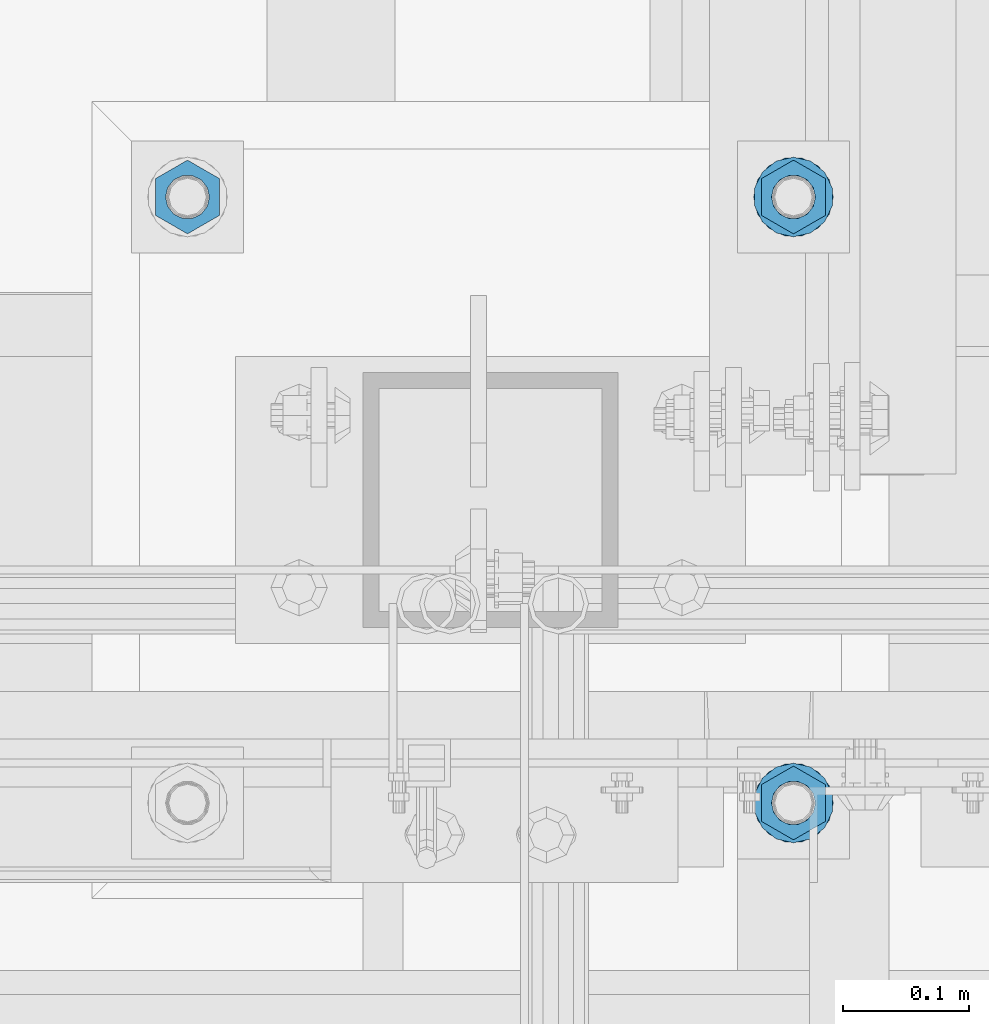
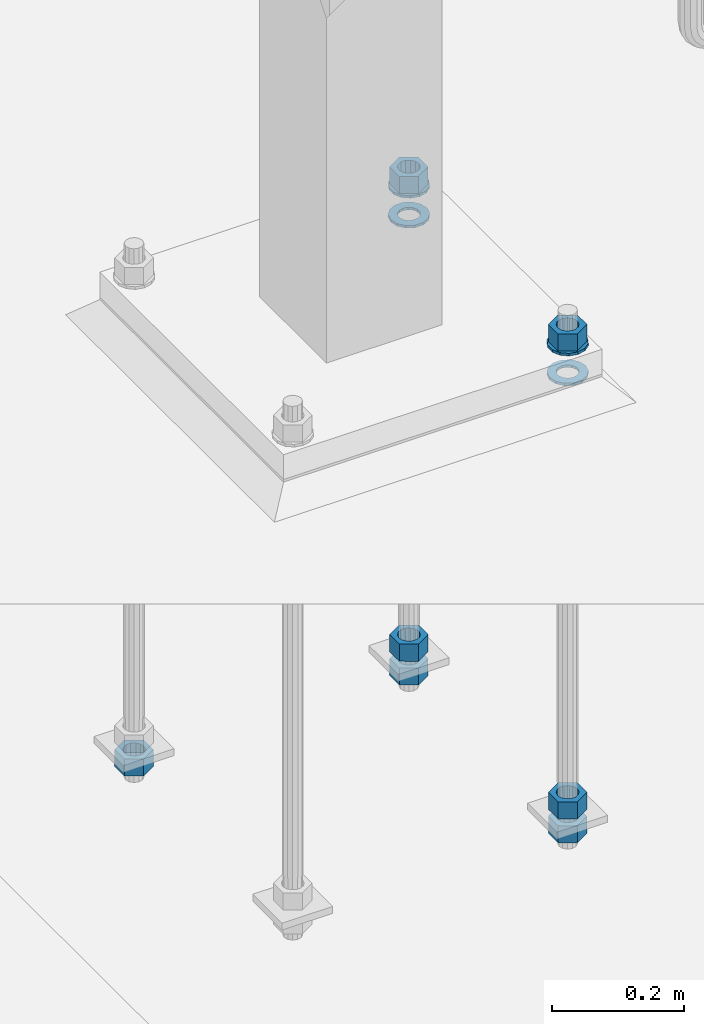
# One storey, part 900 of 1876: 11 columns, 1 element without a shape of its own.
"""IFC2X3 building model written with IfcOpenShell, lengths in millimetres."""

from ifc_helpers import new_model, si_unit, frame, origin_with_axes, place, context, subcontext, project, spatial, faceted_brep, material, type_object, element, aggregate, save


model = new_model("IFC2X3")

# Units and contexts
model_context = context("Model", 3, precision=1e-05, world=origin_with_axes())
body_context = subcontext(model_context, "Body", "Model", "MODEL_VIEW")
ifc_project = project(units=[si_unit("LENGTHUNIT", "METRE", prefix="MILLI"), si_unit("AREAUNIT", "SQUARE_METRE"), si_unit("VOLUMEUNIT", "CUBIC_METRE"), si_unit("MASSUNIT", "GRAM", prefix="KILO"), si_unit("TIMEUNIT", "SECOND"), si_unit("PLANEANGLEUNIT", "RADIAN"), si_unit("SOLIDANGLEUNIT", "STERADIAN"), si_unit("THERMODYNAMICTEMPERATUREUNIT", "DEGREE_CELSIUS"), si_unit("LUMINOUSINTENSITYUNIT", "LUMEN")], contexts=[model_context])

# Site, building, storey
site_placement = place(None, origin_with_axes())
site = spatial("IfcSite", under=ifc_project, at=site_placement, CompositionType="ELEMENT")
building_placement = place(site_placement, origin_with_axes())
building = spatial("IfcBuilding", under=site, at=building_placement, Name="Undefined", CompositionType="ELEMENT")
storey_placement = place(building_placement, origin_with_axes())
storey = spatial("IfcBuildingStorey", under=building, at=storey_placement, Name="Undefined", CompositionType="ELEMENT", Elevation=0.0)

# Assembly, columns
assembly_placement = place(storey_placement, origin_with_axes())
assembly = element("IfcElementAssembly", 1, at=assembly_placement, inside=storey, Name="TEMPLATE", AssemblyPlace="NOTDEFINED", PredefinedType="RIGID_FRAME")
ifc_material_1 = material(Name="STEEL/F436")
column_type_1 = type_object("IfcColumnType", Name="1-1/4_WASHER", PredefinedType="NOTDEFINED")
column_1_placement = place(assembly_placement, frame((1968.5, -4813.3, 38.1), z_axis=(0.0, -1.0, 0.0), x_axis=(0.0, 0.0, -1.0)))
column_1 = element("IfcColumn", 2, at=column_1_placement, type_object=column_type_1, material=ifc_material_1, Name="WASHER", ObjectType="1-1/4_WASHER", context=body_context, shape_type="Brep", body=[
    faceted_brep([(0.0, -31.75, 0.0), (0.0, -28.6057615559018, -13.7758087169823), (4.7625, -28.6057615559018, -13.7758087169823), (4.7625, -31.75, 0.0), (0.0, -19.7958012090148, -24.8231495683603), (4.7625, -19.7958012090148, -24.8231495683603), (0.0, -7.06503965311299, -30.9539612117733), (4.7625, -7.06503965311299, -30.9539612117733), (0.0, 7.06503965311322, -30.9539612117733), (4.7625, 7.06503965311322, -30.9539612117733), (0.0, 19.7958012090151, -24.8231495683603), (4.7625, 19.7958012090151, -24.8231495683603), (0.0, 28.6057615559021, -13.7758087169823), (4.7625, 28.6057615559021, -13.7758087169823), (0.0, 31.75, 0.0), (4.7625, 31.75, 0.0), (0.0, 28.6057615559018, 13.7758087169823), (4.7625, 28.6057615559018, 13.7758087169823), (0.0, 19.7958012090148, 24.8231495683603), (4.7625, 19.7958012090148, 24.8231495683603), (0.0, 7.06503965311299, 30.9539612117733), (4.7625, 7.06503965311299, 30.9539612117733), (0.0, -7.06503965311322, 30.9539612117733), (4.7625, -7.06503965311322, 30.9539612117733), (0.0, -19.7958012090151, 24.8231495683603), (4.7625, -19.7958012090151, 24.8231495683603), (0.0, -28.6057615559021, 13.7758087169823), (4.7625, -28.6057615559021, 13.7758087169823), (0.0, 0.0, 17.4599990844727), (0.0, 7.57560968776033, 15.7309156087144), (4.7625, 7.57560968776011, 15.7309156087149), (4.7625, 0.0, 17.4599990844727), (0.0, 13.6507769681039, 10.8861313696314), (4.7625, 13.6507769681036, 10.8861313696316), (0.0, 17.0222404541219, 3.88521530315325), (4.7625, 17.0222404541214, 3.88521530315302), (0.0, 17.0222404541219, -3.88521530315325), (4.7625, 17.0222404541214, -3.88521530315302), (0.0, 13.6507769681039, -10.8861313696316), (4.7625, 13.6507769681036, -10.8861313696316), (0.0, 7.57560968776033, -15.7309156087147), (4.7625, 7.57560968776011, -15.7309156087149), (0.0, 0.0, -17.4599990844727), (4.7625, 0.0, -17.4599990844727), (0.0, -7.57560968776033, -15.7309156087144), (4.7625, -7.57560968776011, -15.7309156087149), (0.0, -13.6507769681039, -10.8861313696314), (4.7625, -13.6507769681036, -10.8861313696316), (0.0, -17.0222404541219, -3.88521530315325), (4.7625, -17.0222404541214, -3.88521530315302), (0.0, -17.0222404541219, 3.88521530315325), (4.7625, -17.0222404541214, 3.88521530315302), (0.0, -13.6507769681039, 10.8861313696316), (4.7625, -13.6507769681036, 10.8861313696316), (0.0, -7.57560968776033, 15.7309156087147), (4.7625, -7.57560968776011, 15.7309156087149)], [[[0, 1, 2, 3]], [[1, 4, 5, 2]], [[4, 6, 7, 5]], [[6, 8, 9, 7]], [[8, 10, 11, 9]], [[10, 12, 13, 11]], [[12, 14, 15, 13]], [[14, 16, 17, 15]], [[16, 18, 19, 17]], [[18, 20, 21, 19]], [[20, 22, 23, 21]], [[22, 24, 25, 23]], [[24, 26, 27, 25]], [[26, 0, 3, 27]], [[28, 29, 30, 31]], [[29, 32, 33, 30]], [[32, 34, 35, 33]], [[34, 36, 37, 35]], [[36, 38, 39, 37]], [[38, 40, 41, 39]], [[40, 42, 43, 41]], [[42, 44, 45, 43]], [[44, 46, 47, 45]], [[46, 48, 49, 47]], [[48, 50, 51, 49]], [[50, 52, 53, 51]], [[52, 54, 55, 53]], [[54, 28, 31, 55]], [[5, 7, 9, 11, 13, 15, 17, 19, 21, 23, 25, 27, 3, 2], [33, 35, 37, 39, 41, 43, 45, 47, 49, 51, 53, 55, 31, 30]], [[26, 24, 22, 20, 18, 16, 14, 12, 10, 8, 6, 4, 1, 0], [54, 52, 50, 48, 46, 44, 42, 40, 38, 36, 34, 32, 29, 28]]]),
])
column_2_placement = place(assembly_placement, frame((1968.5, -4330.7, 38.1), z_axis=(0.0, -1.0, 0.0), x_axis=(0.0, 0.0, -1.0)))
column_2 = element("IfcColumn", 3, at=column_2_placement, type_object=column_type_1, material=ifc_material_1, Name="WASHER", ObjectType="1-1/4_WASHER", context=body_context, shape_type="Brep", body=[
    faceted_brep([(0.0, -31.75, 0.0), (0.0, -28.6057615559018, -13.7758087169823), (4.7625, -28.6057615559018, -13.7758087169823), (4.7625, -31.75, 0.0), (0.0, -19.7958012090148, -24.8231495683603), (4.7625, -19.7958012090148, -24.8231495683603), (0.0, -7.06503965311299, -30.9539612117733), (4.7625, -7.06503965311299, -30.9539612117733), (0.0, 7.06503965311322, -30.9539612117733), (4.7625, 7.06503965311322, -30.9539612117733), (0.0, 19.7958012090151, -24.8231495683603), (4.7625, 19.7958012090151, -24.8231495683603), (0.0, 28.6057615559021, -13.7758087169823), (4.7625, 28.6057615559021, -13.7758087169823), (0.0, 31.75, 0.0), (4.7625, 31.75, 0.0), (0.0, 28.6057615559018, 13.7758087169823), (4.7625, 28.6057615559018, 13.7758087169823), (0.0, 19.7958012090148, 24.8231495683603), (4.7625, 19.7958012090148, 24.8231495683603), (0.0, 7.06503965311299, 30.9539612117733), (4.7625, 7.06503965311299, 30.9539612117733), (0.0, -7.06503965311322, 30.9539612117733), (4.7625, -7.06503965311322, 30.9539612117733), (0.0, -19.7958012090151, 24.8231495683603), (4.7625, -19.7958012090151, 24.8231495683603), (0.0, -28.6057615559021, 13.7758087169823), (4.7625, -28.6057615559021, 13.7758087169823), (0.0, 0.0, 17.4599990844727), (0.0, 7.57560968776033, 15.7309156087144), (4.7625, 7.57560968776011, 15.7309156087149), (4.7625, 0.0, 17.4599990844727), (0.0, 13.6507769681039, 10.8861313696314), (4.7625, 13.6507769681036, 10.8861313696316), (0.0, 17.0222404541219, 3.88521530315325), (4.7625, 17.0222404541214, 3.88521530315302), (0.0, 17.0222404541219, -3.88521530315325), (4.7625, 17.0222404541214, -3.88521530315302), (0.0, 13.6507769681039, -10.8861313696316), (4.7625, 13.6507769681036, -10.8861313696316), (0.0, 7.57560968776033, -15.7309156087147), (4.7625, 7.57560968776011, -15.7309156087149), (0.0, 0.0, -17.4599990844727), (4.7625, 0.0, -17.4599990844727), (0.0, -7.57560968776033, -15.7309156087144), (4.7625, -7.57560968776011, -15.7309156087149), (0.0, -13.6507769681039, -10.8861313696314), (4.7625, -13.6507769681036, -10.8861313696316), (0.0, -17.0222404541219, -3.88521530315325), (4.7625, -17.0222404541214, -3.88521530315302), (0.0, -17.0222404541219, 3.88521530315325), (4.7625, -17.0222404541214, 3.88521530315302), (0.0, -13.6507769681039, 10.8861313696316), (4.7625, -13.6507769681036, 10.8861313696316), (0.0, -7.57560968776033, 15.7309156087147), (4.7625, -7.57560968776011, 15.7309156087149)], [[[0, 1, 2, 3]], [[1, 4, 5, 2]], [[4, 6, 7, 5]], [[6, 8, 9, 7]], [[8, 10, 11, 9]], [[10, 12, 13, 11]], [[12, 14, 15, 13]], [[14, 16, 17, 15]], [[16, 18, 19, 17]], [[18, 20, 21, 19]], [[20, 22, 23, 21]], [[22, 24, 25, 23]], [[24, 26, 27, 25]], [[26, 0, 3, 27]], [[28, 29, 30, 31]], [[29, 32, 33, 30]], [[32, 34, 35, 33]], [[34, 36, 37, 35]], [[36, 38, 39, 37]], [[38, 40, 41, 39]], [[40, 42, 43, 41]], [[42, 44, 45, 43]], [[44, 46, 47, 45]], [[46, 48, 49, 47]], [[48, 50, 51, 49]], [[50, 52, 53, 51]], [[52, 54, 55, 53]], [[54, 28, 31, 55]], [[5, 7, 9, 11, 13, 15, 17, 19, 21, 23, 25, 27, 3, 2], [33, 35, 37, 39, 41, 43, 45, 47, 49, 51, 53, 55, 31, 30]], [[26, 24, 22, 20, 18, 16, 14, 12, 10, 8, 6, 4, 1, 0], [54, 52, 50, 48, 46, 44, 42, 40, 38, 36, 34, 32, 29, 28]]]),
])
column_3_placement = place(assembly_placement, frame((1968.5, -4813.3, 93.6625), z_axis=(1.0, 0.0, 0.0), x_axis=(0.0, 0.0, -1.0)))
column_3 = element("IfcColumn", 4, at=column_3_placement, type_object=column_type_1, material=ifc_material_1, Name="WASHER", ObjectType="1-1/4_WASHER", context=body_context, shape_type="Brep", body=[
    faceted_brep([(0.0, -31.75, 0.0), (0.0, -28.6057615559018, -13.7758087169823), (4.7625, -28.6057615559018, -13.7758087169823), (4.7625, -31.75, 0.0), (0.0, -19.7958012090148, -24.8231495683603), (4.7625, -19.7958012090148, -24.8231495683603), (0.0, -7.06503965311299, -30.9539612117733), (4.7625, -7.06503965311299, -30.9539612117733), (0.0, 7.06503965311322, -30.9539612117733), (4.7625, 7.06503965311322, -30.9539612117733), (0.0, 19.7958012090151, -24.8231495683603), (4.7625, 19.7958012090151, -24.8231495683603), (0.0, 28.6057615559021, -13.7758087169823), (4.7625, 28.6057615559021, -13.7758087169823), (0.0, 31.75, 0.0), (4.7625, 31.75, 0.0), (0.0, 28.6057615559018, 13.7758087169823), (4.7625, 28.6057615559018, 13.7758087169823), (0.0, 19.7958012090148, 24.8231495683603), (4.7625, 19.7958012090148, 24.8231495683603), (0.0, 7.06503965311299, 30.9539612117733), (4.7625, 7.06503965311299, 30.9539612117733), (0.0, -7.06503965311322, 30.9539612117733), (4.7625, -7.06503965311322, 30.9539612117733), (0.0, -19.7958012090151, 24.8231495683603), (4.7625, -19.7958012090151, 24.8231495683603), (0.0, -28.6057615559021, 13.7758087169823), (4.7625, -28.6057615559021, 13.7758087169823), (0.0, 0.0, 17.4599990844727), (0.0, 7.57560968776033, 15.7309156087144), (4.7625, 7.57560968776011, 15.7309156087149), (4.7625, 0.0, 17.4599990844727), (0.0, 13.6507769681039, 10.8861313696314), (4.7625, 13.6507769681036, 10.8861313696316), (0.0, 17.0222404541219, 3.88521530315325), (4.7625, 17.0222404541214, 3.88521530315302), (0.0, 17.0222404541219, -3.88521530315325), (4.7625, 17.0222404541214, -3.88521530315302), (0.0, 13.6507769681039, -10.8861313696316), (4.7625, 13.6507769681036, -10.8861313696316), (0.0, 7.57560968776033, -15.7309156087147), (4.7625, 7.57560968776011, -15.7309156087149), (0.0, 0.0, -17.4599990844727), (4.7625, 0.0, -17.4599990844727), (0.0, -7.57560968776033, -15.7309156087144), (4.7625, -7.57560968776011, -15.7309156087149), (0.0, -13.6507769681039, -10.8861313696314), (4.7625, -13.6507769681036, -10.8861313696316), (0.0, -17.0222404541219, -3.88521530315325), (4.7625, -17.0222404541214, -3.88521530315302), (0.0, -17.0222404541219, 3.88521530315325), (4.7625, -17.0222404541214, 3.88521530315302), (0.0, -13.6507769681039, 10.8861313696316), (4.7625, -13.6507769681036, 10.8861313696316), (0.0, -7.57560968776033, 15.7309156087147), (4.7625, -7.57560968776011, 15.7309156087149)], [[[0, 1, 2, 3]], [[1, 4, 5, 2]], [[4, 6, 7, 5]], [[6, 8, 9, 7]], [[8, 10, 11, 9]], [[10, 12, 13, 11]], [[12, 14, 15, 13]], [[14, 16, 17, 15]], [[16, 18, 19, 17]], [[18, 20, 21, 19]], [[20, 22, 23, 21]], [[22, 24, 25, 23]], [[24, 26, 27, 25]], [[26, 0, 3, 27]], [[28, 29, 30, 31]], [[29, 32, 33, 30]], [[32, 34, 35, 33]], [[34, 36, 37, 35]], [[36, 38, 39, 37]], [[38, 40, 41, 39]], [[40, 42, 43, 41]], [[42, 44, 45, 43]], [[44, 46, 47, 45]], [[46, 48, 49, 47]], [[48, 50, 51, 49]], [[50, 52, 53, 51]], [[52, 54, 55, 53]], [[54, 28, 31, 55]], [[5, 7, 9, 11, 13, 15, 17, 19, 21, 23, 25, 27, 3, 2], [33, 35, 37, 39, 41, 43, 45, 47, 49, 51, 53, 55, 31, 30]], [[26, 24, 22, 20, 18, 16, 14, 12, 10, 8, 6, 4, 1, 0], [54, 52, 50, 48, 46, 44, 42, 40, 38, 36, 34, 32, 29, 28]]]),
])
column_4_placement = place(assembly_placement, frame((1968.5, -4330.7, 93.6625), z_axis=(-1.0, 0.0, 0.0), x_axis=(0.0, 0.0, -1.0)))
column_4 = element("IfcColumn", 5, at=column_4_placement, type_object=column_type_1, material=ifc_material_1, Name="WASHER", ObjectType="1-1/4_WASHER", context=body_context, shape_type="Brep", body=[
    faceted_brep([(0.0, -31.75, 0.0), (0.0, -28.6057615559018, -13.7758087169823), (4.7625, -28.6057615559018, -13.7758087169823), (4.7625, -31.75, 0.0), (0.0, -19.7958012090148, -24.8231495683603), (4.7625, -19.7958012090148, -24.8231495683603), (0.0, -7.06503965311299, -30.9539612117733), (4.7625, -7.06503965311299, -30.9539612117733), (0.0, 7.06503965311322, -30.9539612117733), (4.7625, 7.06503965311322, -30.9539612117733), (0.0, 19.7958012090151, -24.8231495683603), (4.7625, 19.7958012090151, -24.8231495683603), (0.0, 28.6057615559021, -13.7758087169823), (4.7625, 28.6057615559021, -13.7758087169823), (0.0, 31.75, 0.0), (4.7625, 31.75, 0.0), (0.0, 28.6057615559018, 13.7758087169823), (4.7625, 28.6057615559018, 13.7758087169823), (0.0, 19.7958012090148, 24.8231495683603), (4.7625, 19.7958012090148, 24.8231495683603), (0.0, 7.06503965311299, 30.9539612117733), (4.7625, 7.06503965311299, 30.9539612117733), (0.0, -7.06503965311322, 30.9539612117733), (4.7625, -7.06503965311322, 30.9539612117733), (0.0, -19.7958012090151, 24.8231495683603), (4.7625, -19.7958012090151, 24.8231495683603), (0.0, -28.6057615559021, 13.7758087169823), (4.7625, -28.6057615559021, 13.7758087169823), (0.0, 0.0, 17.4599990844727), (0.0, 7.57560968776033, 15.7309156087144), (4.7625, 7.57560968776011, 15.7309156087149), (4.7625, 0.0, 17.4599990844727), (0.0, 13.6507769681039, 10.8861313696314), (4.7625, 13.6507769681036, 10.8861313696316), (0.0, 17.0222404541219, 3.88521530315325), (4.7625, 17.0222404541214, 3.88521530315302), (0.0, 17.0222404541219, -3.88521530315325), (4.7625, 17.0222404541214, -3.88521530315302), (0.0, 13.6507769681039, -10.8861313696316), (4.7625, 13.6507769681036, -10.8861313696316), (0.0, 7.57560968776033, -15.7309156087147), (4.7625, 7.57560968776011, -15.7309156087149), (0.0, 0.0, -17.4599990844727), (4.7625, 0.0, -17.4599990844727), (0.0, -7.57560968776033, -15.7309156087144), (4.7625, -7.57560968776011, -15.7309156087149), (0.0, -13.6507769681039, -10.8861313696314), (4.7625, -13.6507769681036, -10.8861313696316), (0.0, -17.0222404541219, -3.88521530315325), (4.7625, -17.0222404541214, -3.88521530315302), (0.0, -17.0222404541219, 3.88521530315325), (4.7625, -17.0222404541214, 3.88521530315302), (0.0, -13.6507769681039, 10.8861313696316), (4.7625, -13.6507769681036, 10.8861313696316), (0.0, -7.57560968776033, 15.7309156087147), (4.7625, -7.57560968776011, 15.7309156087149)], [[[0, 1, 2, 3]], [[1, 4, 5, 2]], [[4, 6, 7, 5]], [[6, 8, 9, 7]], [[8, 10, 11, 9]], [[10, 12, 13, 11]], [[12, 14, 15, 13]], [[14, 16, 17, 15]], [[16, 18, 19, 17]], [[18, 20, 21, 19]], [[20, 22, 23, 21]], [[22, 24, 25, 23]], [[24, 26, 27, 25]], [[26, 0, 3, 27]], [[28, 29, 30, 31]], [[29, 32, 33, 30]], [[32, 34, 35, 33]], [[34, 36, 37, 35]], [[36, 38, 39, 37]], [[38, 40, 41, 39]], [[40, 42, 43, 41]], [[42, 44, 45, 43]], [[44, 46, 47, 45]], [[46, 48, 49, 47]], [[48, 50, 51, 49]], [[50, 52, 53, 51]], [[52, 54, 55, 53]], [[54, 28, 31, 55]], [[5, 7, 9, 11, 13, 15, 17, 19, 21, 23, 25, 27, 3, 2], [33, 35, 37, 39, 41, 43, 45, 47, 49, 51, 53, 55, 31, 30]], [[26, 24, 22, 20, 18, 16, 14, 12, 10, 8, 6, 4, 1, 0], [54, 52, 50, 48, 46, 44, 42, 40, 38, 36, 34, 32, 29, 28]]]),
])
ifc_material_2 = material(Name="STEEL/A563")
column_type_2 = type_object("IfcColumnType", Name="1-1/4_HEAVY_HEX_NUT", PredefinedType="NOTDEFINED")
column_5_placement = place(assembly_placement, frame((1968.5, -4813.3, -742.95), z_axis=(1.0, 0.0, 0.0), x_axis=(0.0, 0.0, -1.0)))
column_5 = element("IfcColumn", 6, at=column_5_placement, type_object=column_type_2, material=ifc_material_2, Name="NUT", ObjectType="1-1/4_HEAVY_HEX_NUT", context=body_context, shape_type="Brep", body=[
    faceted_brep([(0.0, -29.3700008392334, 0.0), (0.0, -14.6800003051758, -25.4300003051758), (31.75, -14.6800003051758, -25.4300003051758), (31.75, -29.3700008392334, 0.0), (0.0, 14.6800003051758, -25.4300003051758), (31.75, 14.6800003051758, -25.4300003051758), (0.0, 29.3700008392334, 0.0), (31.75, 29.3700008392334, 0.0), (0.0, 14.6800003051758, 25.4300003051758), (31.75, 14.6800003051758, 25.4300003051758), (0.0, -14.6800003051758, 25.4300003051758), (31.75, -14.6800003051758, 25.4300003051758), (0.0, 0.0, 17.4599990844727), (0.0, 7.57560968776033, 15.7309156087144), (31.75, 7.57560968776033, 15.7309156087144), (31.75, 0.0, 17.4599990844727), (0.0, 13.6507769681039, 10.8861313696314), (31.75, 13.6507769681039, 10.8861313696314), (0.0, 17.0222404541219, 3.88521530315325), (31.75, 17.0222404541219, 3.88521530315325), (0.0, 17.0222404541219, -3.88521530315325), (31.75, 17.0222404541219, -3.88521530315325), (0.0, 13.6507769681039, -10.8861313696316), (31.75, 13.6507769681039, -10.8861313696316), (0.0, 7.57560968776033, -15.7309156087147), (31.75, 7.57560968776033, -15.7309156087147), (0.0, 0.0, -17.4599990844727), (31.75, 0.0, -17.4599990844727), (0.0, -7.57560968776033, -15.7309156087144), (31.75, -7.57560968776033, -15.7309156087144), (0.0, -13.6507769681039, -10.8861313696314), (31.75, -13.6507769681039, -10.8861313696314), (0.0, -17.0222404541219, -3.88521530315325), (31.75, -17.0222404541219, -3.88521530315325), (0.0, -17.0222404541219, 3.88521530315325), (31.75, -17.0222404541219, 3.88521530315325), (0.0, -13.6507769681039, 10.8861313696316), (31.75, -13.6507769681039, 10.8861313696316), (0.0, -7.57560968776033, 15.7309156087147), (31.75, -7.57560968776033, 15.7309156087147)], [[[0, 1, 2, 3]], [[1, 4, 5, 2]], [[4, 6, 7, 5]], [[6, 8, 9, 7]], [[8, 10, 11, 9]], [[10, 0, 3, 11]], [[12, 13, 14, 15]], [[13, 16, 17, 14]], [[16, 18, 19, 17]], [[18, 20, 21, 19]], [[20, 22, 23, 21]], [[22, 24, 25, 23]], [[24, 26, 27, 25]], [[26, 28, 29, 27]], [[28, 30, 31, 29]], [[30, 32, 33, 31]], [[32, 34, 35, 33]], [[34, 36, 37, 35]], [[36, 38, 39, 37]], [[38, 12, 15, 39]], [[5, 7, 9, 11, 3, 2], [17, 19, 21, 23, 25, 27, 29, 31, 33, 35, 37, 39, 15, 14]], [[10, 8, 6, 4, 1, 0], [38, 36, 34, 32, 30, 28, 26, 24, 22, 20, 18, 16, 13, 12]]]),
])
column_6_placement = place(assembly_placement, frame((1968.5, -4330.7, -742.95), z_axis=(-1.0, 0.0, 0.0), x_axis=(0.0, 0.0, -1.0)))
column_6 = element("IfcColumn", 7, at=column_6_placement, type_object=column_type_2, material=ifc_material_2, Name="NUT", ObjectType="1-1/4_HEAVY_HEX_NUT", context=body_context, shape_type="Brep", body=[
    faceted_brep([(0.0, -29.3700008392334, 0.0), (0.0, -14.6800003051758, -25.4300003051758), (31.75, -14.6800003051758, -25.4300003051758), (31.75, -29.3700008392334, 0.0), (0.0, 14.6800003051758, -25.4300003051758), (31.75, 14.6800003051758, -25.4300003051758), (0.0, 29.3700008392334, 0.0), (31.75, 29.3700008392334, 0.0), (0.0, 14.6800003051758, 25.4300003051758), (31.75, 14.6800003051758, 25.4300003051758), (0.0, -14.6800003051758, 25.4300003051758), (31.75, -14.6800003051758, 25.4300003051758), (0.0, 0.0, 17.4599990844727), (0.0, 7.57560968776033, 15.7309156087144), (31.75, 7.57560968776033, 15.7309156087144), (31.75, 0.0, 17.4599990844727), (0.0, 13.6507769681039, 10.8861313696314), (31.75, 13.6507769681039, 10.8861313696314), (0.0, 17.0222404541219, 3.88521530315325), (31.75, 17.0222404541219, 3.88521530315325), (0.0, 17.0222404541219, -3.88521530315325), (31.75, 17.0222404541219, -3.88521530315325), (0.0, 13.6507769681039, -10.8861313696316), (31.75, 13.6507769681039, -10.8861313696316), (0.0, 7.57560968776033, -15.7309156087147), (31.75, 7.57560968776033, -15.7309156087147), (0.0, 0.0, -17.4599990844727), (31.75, 0.0, -17.4599990844727), (0.0, -7.57560968776033, -15.7309156087144), (31.75, -7.57560968776033, -15.7309156087144), (0.0, -13.6507769681039, -10.8861313696314), (31.75, -13.6507769681039, -10.8861313696314), (0.0, -17.0222404541219, -3.88521530315325), (31.75, -17.0222404541219, -3.88521530315325), (0.0, -17.0222404541219, 3.88521530315325), (31.75, -17.0222404541219, 3.88521530315325), (0.0, -13.6507769681039, 10.8861313696316), (31.75, -13.6507769681039, 10.8861313696316), (0.0, -7.57560968776033, 15.7309156087147), (31.75, -7.57560968776033, 15.7309156087147)], [[[0, 1, 2, 3]], [[1, 4, 5, 2]], [[4, 6, 7, 5]], [[6, 8, 9, 7]], [[8, 10, 11, 9]], [[10, 0, 3, 11]], [[12, 13, 14, 15]], [[13, 16, 17, 14]], [[16, 18, 19, 17]], [[18, 20, 21, 19]], [[20, 22, 23, 21]], [[22, 24, 25, 23]], [[24, 26, 27, 25]], [[26, 28, 29, 27]], [[28, 30, 31, 29]], [[30, 32, 33, 31]], [[32, 34, 35, 33]], [[34, 36, 37, 35]], [[36, 38, 39, 37]], [[38, 12, 15, 39]], [[5, 7, 9, 11, 3, 2], [17, 19, 21, 23, 25, 27, 29, 31, 33, 35, 37, 39, 15, 14]], [[10, 8, 6, 4, 1, 0], [38, 36, 34, 32, 30, 28, 26, 24, 22, 20, 18, 16, 13, 12]]]),
])
column_7_placement = place(assembly_placement, frame((1968.5, -4813.3, 125.4125), z_axis=(1.0, 0.0, 0.0), x_axis=(0.0, 0.0, -1.0)))
column_7 = element("IfcColumn", 8, at=column_7_placement, type_object=column_type_2, material=ifc_material_2, Name="NUT", ObjectType="1-1/4_HEAVY_HEX_NUT", context=body_context, shape_type="Brep", body=[
    faceted_brep([(0.0, -29.3700008392334, 0.0), (0.0, -14.6800003051758, -25.4300003051758), (31.75, -14.6800003051758, -25.4300003051758), (31.75, -29.3700008392334, 0.0), (0.0, 14.6800003051758, -25.4300003051758), (31.75, 14.6800003051758, -25.4300003051758), (0.0, 29.3700008392334, 0.0), (31.75, 29.3700008392334, 0.0), (0.0, 14.6800003051758, 25.4300003051758), (31.75, 14.6800003051758, 25.4300003051758), (0.0, -14.6800003051758, 25.4300003051758), (31.75, -14.6800003051758, 25.4300003051758), (0.0, 0.0, 17.4599990844727), (0.0, 7.57560968776033, 15.7309156087144), (31.75, 7.57560968776033, 15.7309156087144), (31.75, 0.0, 17.4599990844727), (0.0, 13.6507769681039, 10.8861313696314), (31.75, 13.6507769681039, 10.8861313696314), (0.0, 17.0222404541219, 3.88521530315325), (31.75, 17.0222404541219, 3.88521530315325), (0.0, 17.0222404541219, -3.88521530315325), (31.75, 17.0222404541219, -3.88521530315325), (0.0, 13.6507769681039, -10.8861313696316), (31.75, 13.6507769681039, -10.8861313696316), (0.0, 7.57560968776033, -15.7309156087147), (31.75, 7.57560968776033, -15.7309156087147), (0.0, 0.0, -17.4599990844727), (31.75, 0.0, -17.4599990844727), (0.0, -7.57560968776033, -15.7309156087144), (31.75, -7.57560968776033, -15.7309156087144), (0.0, -13.6507769681039, -10.8861313696314), (31.75, -13.6507769681039, -10.8861313696314), (0.0, -17.0222404541219, -3.88521530315325), (31.75, -17.0222404541219, -3.88521530315325), (0.0, -17.0222404541219, 3.88521530315325), (31.75, -17.0222404541219, 3.88521530315325), (0.0, -13.6507769681039, 10.8861313696316), (31.75, -13.6507769681039, 10.8861313696316), (0.0, -7.57560968776033, 15.7309156087147), (31.75, -7.57560968776033, 15.7309156087147)], [[[0, 1, 2, 3]], [[1, 4, 5, 2]], [[4, 6, 7, 5]], [[6, 8, 9, 7]], [[8, 10, 11, 9]], [[10, 0, 3, 11]], [[12, 13, 14, 15]], [[13, 16, 17, 14]], [[16, 18, 19, 17]], [[18, 20, 21, 19]], [[20, 22, 23, 21]], [[22, 24, 25, 23]], [[24, 26, 27, 25]], [[26, 28, 29, 27]], [[28, 30, 31, 29]], [[30, 32, 33, 31]], [[32, 34, 35, 33]], [[34, 36, 37, 35]], [[36, 38, 39, 37]], [[38, 12, 15, 39]], [[5, 7, 9, 11, 3, 2], [17, 19, 21, 23, 25, 27, 29, 31, 33, 35, 37, 39, 15, 14]], [[10, 8, 6, 4, 1, 0], [38, 36, 34, 32, 30, 28, 26, 24, 22, 20, 18, 16, 13, 12]]]),
])
column_8_placement = place(assembly_placement, frame((1968.5, -4813.3, -787.4), z_axis=(1.0, 0.0, 0.0), x_axis=(0.0, 0.0, -1.0)))
column_8 = element("IfcColumn", 9, at=column_8_placement, type_object=column_type_2, material=ifc_material_2, Name="NUT", ObjectType="1-1/4_HEAVY_HEX_NUT", context=body_context, shape_type="Brep", body=[
    faceted_brep([(0.0, -29.3700008392334, 0.0), (0.0, -14.6800003051758, -25.4300003051758), (31.75, -14.6800003051758, -25.4300003051758), (31.75, -29.3700008392334, 0.0), (0.0, 14.6800003051758, -25.4300003051758), (31.75, 14.6800003051758, -25.4300003051758), (0.0, 29.3700008392334, 0.0), (31.75, 29.3700008392334, 0.0), (0.0, 14.6800003051758, 25.4300003051758), (31.75, 14.6800003051758, 25.4300003051758), (0.0, -14.6800003051758, 25.4300003051758), (31.75, -14.6800003051758, 25.4300003051758), (0.0, 0.0, 17.4599990844727), (0.0, 7.57560968776033, 15.7309156087144), (31.75, 7.57560968776033, 15.7309156087144), (31.75, 0.0, 17.4599990844727), (0.0, 13.6507769681039, 10.8861313696314), (31.75, 13.6507769681039, 10.8861313696314), (0.0, 17.0222404541219, 3.88521530315325), (31.75, 17.0222404541219, 3.88521530315325), (0.0, 17.0222404541219, -3.88521530315325), (31.75, 17.0222404541219, -3.88521530315325), (0.0, 13.6507769681039, -10.8861313696316), (31.75, 13.6507769681039, -10.8861313696316), (0.0, 7.57560968776033, -15.7309156087147), (31.75, 7.57560968776033, -15.7309156087147), (0.0, 0.0, -17.4599990844727), (31.75, 0.0, -17.4599990844727), (0.0, -7.57560968776033, -15.7309156087144), (31.75, -7.57560968776033, -15.7309156087144), (0.0, -13.6507769681039, -10.8861313696314), (31.75, -13.6507769681039, -10.8861313696314), (0.0, -17.0222404541219, -3.88521530315325), (31.75, -17.0222404541219, -3.88521530315325), (0.0, -17.0222404541219, 3.88521530315325), (31.75, -17.0222404541219, 3.88521530315325), (0.0, -13.6507769681039, 10.8861313696316), (31.75, -13.6507769681039, 10.8861313696316), (0.0, -7.57560968776033, 15.7309156087147), (31.75, -7.57560968776033, 15.7309156087147)], [[[0, 1, 2, 3]], [[1, 4, 5, 2]], [[4, 6, 7, 5]], [[6, 8, 9, 7]], [[8, 10, 11, 9]], [[10, 0, 3, 11]], [[12, 13, 14, 15]], [[13, 16, 17, 14]], [[16, 18, 19, 17]], [[18, 20, 21, 19]], [[20, 22, 23, 21]], [[22, 24, 25, 23]], [[24, 26, 27, 25]], [[26, 28, 29, 27]], [[28, 30, 31, 29]], [[30, 32, 33, 31]], [[32, 34, 35, 33]], [[34, 36, 37, 35]], [[36, 38, 39, 37]], [[38, 12, 15, 39]], [[5, 7, 9, 11, 3, 2], [17, 19, 21, 23, 25, 27, 29, 31, 33, 35, 37, 39, 15, 14]], [[10, 8, 6, 4, 1, 0], [38, 36, 34, 32, 30, 28, 26, 24, 22, 20, 18, 16, 13, 12]]]),
])
column_9_placement = place(assembly_placement, frame((1968.5, -4330.7, 125.4125), z_axis=(-1.0, 0.0, 0.0), x_axis=(0.0, 0.0, -1.0)))
column_9 = element("IfcColumn", 10, at=column_9_placement, type_object=column_type_2, material=ifc_material_2, Name="NUT", ObjectType="1-1/4_HEAVY_HEX_NUT", context=body_context, shape_type="Brep", body=[
    faceted_brep([(0.0, -29.3700008392334, 0.0), (0.0, -14.6800003051758, -25.4300003051758), (31.75, -14.6800003051758, -25.4300003051758), (31.75, -29.3700008392334, 0.0), (0.0, 14.6800003051758, -25.4300003051758), (31.75, 14.6800003051758, -25.4300003051758), (0.0, 29.3700008392334, 0.0), (31.75, 29.3700008392334, 0.0), (0.0, 14.6800003051758, 25.4300003051758), (31.75, 14.6800003051758, 25.4300003051758), (0.0, -14.6800003051758, 25.4300003051758), (31.75, -14.6800003051758, 25.4300003051758), (0.0, 0.0, 17.4599990844727), (0.0, 7.57560968776033, 15.7309156087144), (31.75, 7.57560968776033, 15.7309156087144), (31.75, 0.0, 17.4599990844727), (0.0, 13.6507769681039, 10.8861313696314), (31.75, 13.6507769681039, 10.8861313696314), (0.0, 17.0222404541219, 3.88521530315325), (31.75, 17.0222404541219, 3.88521530315325), (0.0, 17.0222404541219, -3.88521530315325), (31.75, 17.0222404541219, -3.88521530315325), (0.0, 13.6507769681039, -10.8861313696316), (31.75, 13.6507769681039, -10.8861313696316), (0.0, 7.57560968776033, -15.7309156087147), (31.75, 7.57560968776033, -15.7309156087147), (0.0, 0.0, -17.4599990844727), (31.75, 0.0, -17.4599990844727), (0.0, -7.57560968776033, -15.7309156087144), (31.75, -7.57560968776033, -15.7309156087144), (0.0, -13.6507769681039, -10.8861313696314), (31.75, -13.6507769681039, -10.8861313696314), (0.0, -17.0222404541219, -3.88521530315325), (31.75, -17.0222404541219, -3.88521530315325), (0.0, -17.0222404541219, 3.88521530315325), (31.75, -17.0222404541219, 3.88521530315325), (0.0, -13.6507769681039, 10.8861313696316), (31.75, -13.6507769681039, 10.8861313696316), (0.0, -7.57560968776033, 15.7309156087147), (31.75, -7.57560968776033, 15.7309156087147)], [[[0, 1, 2, 3]], [[1, 4, 5, 2]], [[4, 6, 7, 5]], [[6, 8, 9, 7]], [[8, 10, 11, 9]], [[10, 0, 3, 11]], [[12, 13, 14, 15]], [[13, 16, 17, 14]], [[16, 18, 19, 17]], [[18, 20, 21, 19]], [[20, 22, 23, 21]], [[22, 24, 25, 23]], [[24, 26, 27, 25]], [[26, 28, 29, 27]], [[28, 30, 31, 29]], [[30, 32, 33, 31]], [[32, 34, 35, 33]], [[34, 36, 37, 35]], [[36, 38, 39, 37]], [[38, 12, 15, 39]], [[5, 7, 9, 11, 3, 2], [17, 19, 21, 23, 25, 27, 29, 31, 33, 35, 37, 39, 15, 14]], [[10, 8, 6, 4, 1, 0], [38, 36, 34, 32, 30, 28, 26, 24, 22, 20, 18, 16, 13, 12]]]),
])
column_10_placement = place(assembly_placement, frame((1968.5, -4330.7, -787.4), z_axis=(-1.0, 0.0, 0.0), x_axis=(0.0, 0.0, -1.0)))
column_10 = element("IfcColumn", 11, at=column_10_placement, type_object=column_type_2, material=ifc_material_2, Name="NUT", ObjectType="1-1/4_HEAVY_HEX_NUT", context=body_context, shape_type="Brep", body=[
    faceted_brep([(0.0, -29.3700008392334, 0.0), (0.0, -14.6800003051758, -25.4300003051758), (31.75, -14.6800003051758, -25.4300003051758), (31.75, -29.3700008392334, 0.0), (0.0, 14.6800003051758, -25.4300003051758), (31.75, 14.6800003051758, -25.4300003051758), (0.0, 29.3700008392334, 0.0), (31.75, 29.3700008392334, 0.0), (0.0, 14.6800003051758, 25.4300003051758), (31.75, 14.6800003051758, 25.4300003051758), (0.0, -14.6800003051758, 25.4300003051758), (31.75, -14.6800003051758, 25.4300003051758), (0.0, 0.0, 17.4599990844727), (0.0, 7.57560968776033, 15.7309156087144), (31.75, 7.57560968776033, 15.7309156087144), (31.75, 0.0, 17.4599990844727), (0.0, 13.6507769681039, 10.8861313696314), (31.75, 13.6507769681039, 10.8861313696314), (0.0, 17.0222404541219, 3.88521530315325), (31.75, 17.0222404541219, 3.88521530315325), (0.0, 17.0222404541219, -3.88521530315325), (31.75, 17.0222404541219, -3.88521530315325), (0.0, 13.6507769681039, -10.8861313696316), (31.75, 13.6507769681039, -10.8861313696316), (0.0, 7.57560968776033, -15.7309156087147), (31.75, 7.57560968776033, -15.7309156087147), (0.0, 0.0, -17.4599990844727), (31.75, 0.0, -17.4599990844727), (0.0, -7.57560968776033, -15.7309156087144), (31.75, -7.57560968776033, -15.7309156087144), (0.0, -13.6507769681039, -10.8861313696314), (31.75, -13.6507769681039, -10.8861313696314), (0.0, -17.0222404541219, -3.88521530315325), (31.75, -17.0222404541219, -3.88521530315325), (0.0, -17.0222404541219, 3.88521530315325), (31.75, -17.0222404541219, 3.88521530315325), (0.0, -13.6507769681039, 10.8861313696316), (31.75, -13.6507769681039, 10.8861313696316), (0.0, -7.57560968776033, 15.7309156087147), (31.75, -7.57560968776033, 15.7309156087147)], [[[0, 1, 2, 3]], [[1, 4, 5, 2]], [[4, 6, 7, 5]], [[6, 8, 9, 7]], [[8, 10, 11, 9]], [[10, 0, 3, 11]], [[12, 13, 14, 15]], [[13, 16, 17, 14]], [[16, 18, 19, 17]], [[18, 20, 21, 19]], [[20, 22, 23, 21]], [[22, 24, 25, 23]], [[24, 26, 27, 25]], [[26, 28, 29, 27]], [[28, 30, 31, 29]], [[30, 32, 33, 31]], [[32, 34, 35, 33]], [[34, 36, 37, 35]], [[36, 38, 39, 37]], [[38, 12, 15, 39]], [[5, 7, 9, 11, 3, 2], [17, 19, 21, 23, 25, 27, 29, 31, 33, 35, 37, 39, 15, 14]], [[10, 8, 6, 4, 1, 0], [38, 36, 34, 32, 30, 28, 26, 24, 22, 20, 18, 16, 13, 12]]]),
])
column_11_placement = place(assembly_placement, frame((1485.9, -4330.7, -787.4), z_axis=(-1.0, 0.0, 0.0), x_axis=(0.0, 0.0, -1.0)))
column_11 = element("IfcColumn", 12, at=column_11_placement, type_object=column_type_2, material=ifc_material_2, Name="NUT", ObjectType="1-1/4_HEAVY_HEX_NUT", context=body_context, shape_type="Brep", body=[
    faceted_brep([(0.0, -29.3700008392334, 0.0), (0.0, -14.6800003051758, -25.4300003051758), (31.75, -14.6800003051758, -25.4300003051758), (31.75, -29.3700008392334, 0.0), (0.0, 14.6800003051758, -25.4300003051758), (31.75, 14.6800003051758, -25.4300003051758), (0.0, 29.3700008392334, 0.0), (31.75, 29.3700008392334, 0.0), (0.0, 14.6800003051758, 25.4300003051758), (31.75, 14.6800003051758, 25.4300003051758), (0.0, -14.6800003051758, 25.4300003051758), (31.75, -14.6800003051758, 25.4300003051758), (0.0, 0.0, 17.4599990844727), (0.0, 7.57560968776033, 15.7309156087144), (31.75, 7.57560968776033, 15.7309156087144), (31.75, 0.0, 17.4599990844727), (0.0, 13.6507769681039, 10.8861313696314), (31.75, 13.6507769681039, 10.8861313696314), (0.0, 17.0222404541219, 3.88521530315325), (31.75, 17.0222404541219, 3.88521530315325), (0.0, 17.0222404541219, -3.88521530315325), (31.75, 17.0222404541219, -3.88521530315325), (0.0, 13.6507769681039, -10.8861313696316), (31.75, 13.6507769681039, -10.8861313696316), (0.0, 7.57560968776033, -15.7309156087147), (31.75, 7.57560968776033, -15.7309156087147), (0.0, 0.0, -17.4599990844727), (31.75, 0.0, -17.4599990844727), (0.0, -7.57560968776033, -15.7309156087144), (31.75, -7.57560968776033, -15.7309156087144), (0.0, -13.6507769681039, -10.8861313696314), (31.75, -13.6507769681039, -10.8861313696314), (0.0, -17.0222404541219, -3.88521530315325), (31.75, -17.0222404541219, -3.88521530315325), (0.0, -17.0222404541219, 3.88521530315325), (31.75, -17.0222404541219, 3.88521530315325), (0.0, -13.6507769681039, 10.8861313696316), (31.75, -13.6507769681039, 10.8861313696316), (0.0, -7.57560968776033, 15.7309156087147), (31.75, -7.57560968776033, 15.7309156087147)], [[[0, 1, 2, 3]], [[1, 4, 5, 2]], [[4, 6, 7, 5]], [[6, 8, 9, 7]], [[8, 10, 11, 9]], [[10, 0, 3, 11]], [[12, 13, 14, 15]], [[13, 16, 17, 14]], [[16, 18, 19, 17]], [[18, 20, 21, 19]], [[20, 22, 23, 21]], [[22, 24, 25, 23]], [[24, 26, 27, 25]], [[26, 28, 29, 27]], [[28, 30, 31, 29]], [[30, 32, 33, 31]], [[32, 34, 35, 33]], [[34, 36, 37, 35]], [[36, 38, 39, 37]], [[38, 12, 15, 39]], [[5, 7, 9, 11, 3, 2], [17, 19, 21, 23, 25, 27, 29, 31, 33, 35, 37, 39, 15, 14]], [[10, 8, 6, 4, 1, 0], [38, 36, 34, 32, 30, 28, 26, 24, 22, 20, 18, 16, 13, 12]]]),
])
aggregate(assembly, [column_1, column_2, column_5, column_6, column_7, column_3, column_8, column_9, column_4, column_10, column_11])

save(model, "model.ifc")
